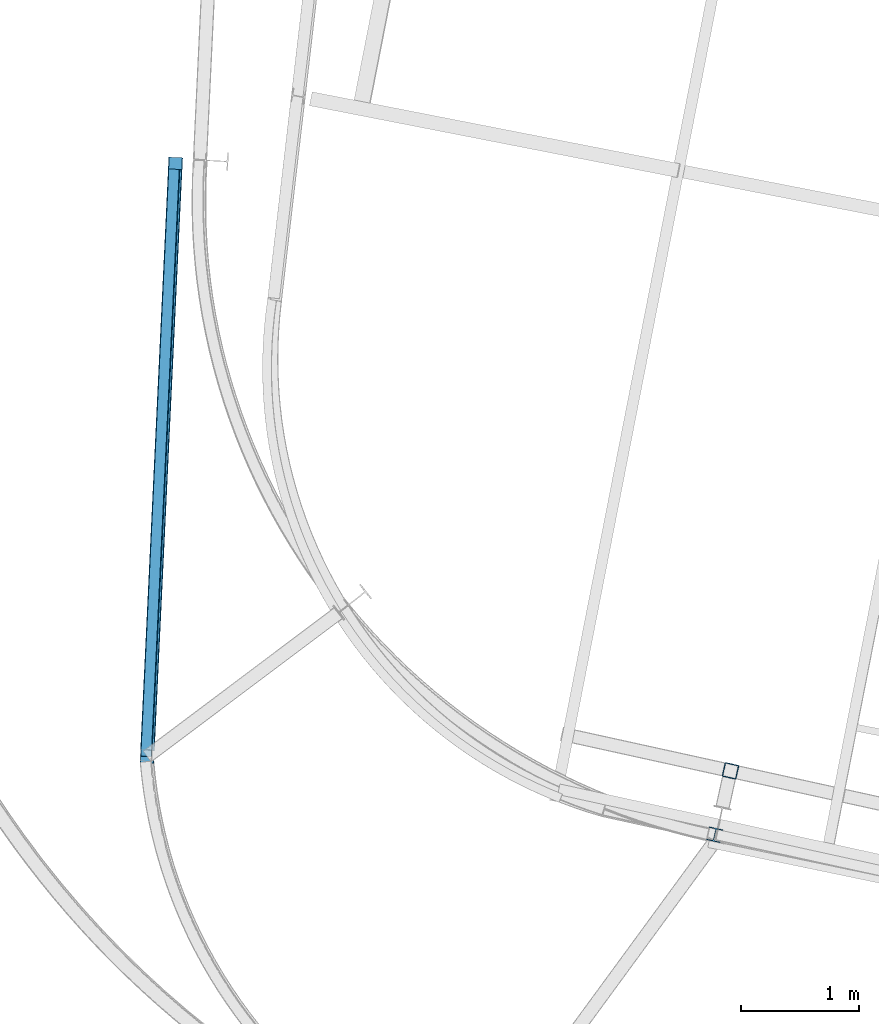
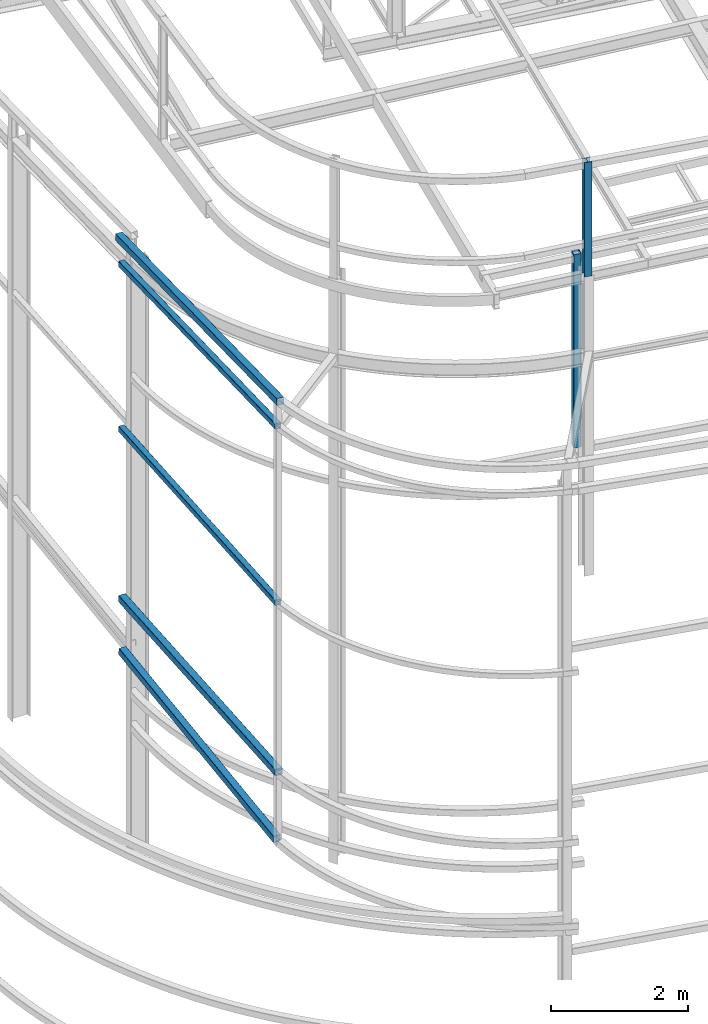
# One storey, part 18 of 215: 7 beams, 7 elements without a shape of their own.
"""IFC2X3 building model written with IfcOpenShell, lengths in millimetres."""

from ifc_helpers import new_model, si_unit, frame, origin_with_axes, origin_2d_with_axis, place, context, subcontext, project, spatial, hollow_rectangle, i_section, extrude, material, type_object, element, aggregate, save


model = new_model("IFC2X3")

# Units and contexts
model_context = context("Model", 3, precision=1e-05, world=origin_with_axes())
body_context = subcontext(model_context, "Body", "Model", "MODEL_VIEW")
ifc_project = project(units=[si_unit("LENGTHUNIT", "METRE", prefix="MILLI"), si_unit("AREAUNIT", "SQUARE_METRE"), si_unit("VOLUMEUNIT", "CUBIC_METRE"), si_unit("MASSUNIT", "GRAM", prefix="KILO"), si_unit("TIMEUNIT", "SECOND"), si_unit("PLANEANGLEUNIT", "RADIAN"), si_unit("SOLIDANGLEUNIT", "STERADIAN"), si_unit("THERMODYNAMICTEMPERATUREUNIT", "DEGREE_CELSIUS"), si_unit("LUMINOUSINTENSITYUNIT", "LUMEN")], contexts=[model_context])

# Site, building, storey
site_placement = place(None, origin_with_axes())
site = spatial("IfcSite", under=ifc_project, at=site_placement, CompositionType="ELEMENT")
building_placement = place(site_placement, origin_with_axes())
building = spatial("IfcBuilding", under=site, at=building_placement, Name="Undefined", CompositionType="ELEMENT")
storey_placement = place(building_placement, origin_with_axes())
storey = spatial("IfcBuildingStorey", under=building, at=storey_placement, Name="Undefined", CompositionType="ELEMENT", Elevation=0.0)

# Assembly, beam
assembly_1_placement = place(storey_placement, origin_with_axes())
assembly_1 = element("IfcElementAssembly", 1, at=assembly_1_placement, inside=storey, Name="Steel Assembly", AssemblyPlace="NOTDEFINED", PredefinedType="RIGID_FRAME")
ifc_material = material(Name="STEEL/S275JR")
beam_type_1 = type_object("IfcBeamType", PredefinedType="NOTDEFINED")
beam_1_placement = place(assembly_1_placement, frame((36795.3247404599, 11460.41995252, 11240.3737871053), z_axis=(0.00238075000008834, 0.049957779001925, 0.998748493038479), x_axis=(0.0475416480028052, 0.997616331058868, -0.0500144750029513)))
beam_1 = element("IfcBeam", 2, at=beam_1_placement, type_object=beam_type_1, material=ifc_material, Name="LISSE", context=body_context, shape_type="SweptSolid", body=[
    extrude(hollow_rectangle(XDim=120.0, YDim=120.0, WallThickness=4.0, InnerFilletRadius=4.0, OuterFilletRadius=8.0, at=origin_2d_with_axis()), frame((5139.48581661668, 7.27365367368595e-12, -5.45696821063757e-12), z_axis=(-1.0, 0.0, 0.0), x_axis=(-6.93889390390723e-18, -1.0, -3.46944695195361e-18)), (0.0, 0.0, 1.0), 5139.5),
])
aggregate(assembly_1, [beam_1])

assembly_2_placement = place(storey_placement, origin_with_axes())
assembly_2 = element("IfcElementAssembly", 3, at=assembly_2_placement, inside=storey, Name="Steel Assembly", AssemblyPlace="NOTDEFINED", PredefinedType="RIGID_FRAME")
beam_type_2 = type_object("IfcBeamType", PredefinedType="NOTDEFINED")
beam_2_placement = place(assembly_2_placement, frame((41739.3919223138, 11394.2173397851, 12210.2118217111), z_axis=(-0.214538758981639, -0.97671547591641, 0.0), x_axis=(0.0, 0.0, -1.0)))
beam_2 = element("IfcBeam", 4, at=beam_2_placement, type_object=beam_type_2, material=ifc_material, Name="LISSE", context=body_context, shape_type="SweptSolid", body=[
    extrude(hollow_rectangle(XDim=120.0, YDim=120.0, WallThickness=5.0, InnerFilletRadius=5.0, OuterFilletRadius=10.0, at=origin_2d_with_axis()), frame((3444.21098008439, 7.2759576369753e-12, 3.73929221960184e-21), z_axis=(-1.0, 0.0, 0.0), x_axis=(-6.93889390390723e-18, -1.0, -3.46944695195361e-18)), (0.0, 0.0, 1.0), 3444.2),
])
aggregate(assembly_2, [beam_2])

assembly_3_placement = place(storey_placement, origin_with_axes())
assembly_3 = element("IfcElementAssembly", 5, at=assembly_3_placement, inside=storey, Name="Steel Assembly", AssemblyPlace="NOTDEFINED", PredefinedType="RIGID_FRAME")
beam_3_placement = place(assembly_3_placement, frame((36800.4836915666, 11570.7503925782, 3388.42358772173), z_axis=(-0.00280173800110912, -0.0584249270230884, 0.998287873394503), x_axis=(0.047541444015522, 0.997155198325569, 0.0584920640190976)))
beam_3 = element("IfcBeam", 6, at=beam_3_placement, type_object=beam_type_2, material=ifc_material, Name="LISSE", context=body_context, shape_type="SweptSolid", body=[
    extrude(hollow_rectangle(XDim=120.0, YDim=120.0, WallThickness=5.0, InnerFilletRadius=5.0, OuterFilletRadius=10.0, at=origin_2d_with_axis()), frame((4926.01569208884, -3.74450364960788e-14, -9.09494701772928e-13), z_axis=(-1.0, 0.0, 0.0), x_axis=(-6.93889390390723e-18, -1.0, -3.46944695195361e-18)), (0.0, 0.0, 1.0), 4926.0),
])
aggregate(assembly_3, [beam_3])

assembly_4_placement = place(storey_placement, origin_with_axes())
assembly_4 = element("IfcElementAssembly", 7, at=assembly_4_placement, inside=storey, Name="Steel Assembly", AssemblyPlace="NOTDEFINED", PredefinedType="RIGID_FRAME")
beam_4_placement = place(assembly_4_placement, frame((36798.0156396208, 11516.4725905369, 4609.93424743849), z_axis=(3.64340000136608e-05, -1.73599999892668e-06, 0.999999999334775), x_axis=(0.0475972750198219, 0.998866607415969, 0.0)))
beam_4 = element("IfcBeam", 8, at=beam_4_placement, type_object=beam_type_2, material=ifc_material, Name="LISSE", context=body_context, shape_type="SweptSolid", body=[
    extrude(hollow_rectangle(XDim=120.0, YDim=120.0, WallThickness=5.0, InnerFilletRadius=5.0, OuterFilletRadius=10.0, at=origin_2d_with_axis()), frame((4980.06278256892, 6.91122545660855e-14, -9.09496810911556e-13), z_axis=(-1.0, 0.0, 0.0), x_axis=(-6.93889390390723e-18, -1.0, -3.46944695195361e-18)), (0.0, 0.0, 1.0), 4980.1),
])
aggregate(assembly_4, [beam_4])

assembly_5_placement = place(storey_placement, origin_with_axes())
assembly_5 = element("IfcElementAssembly", 9, at=assembly_5_placement, inside=storey, Name="Steel Assembly", AssemblyPlace="NOTDEFINED", PredefinedType="RIGID_FRAME")
beam_type_3 = type_object("IfcBeamType", PredefinedType="NOTDEFINED")
beam_5_placement = place(assembly_5_placement, frame((36788.0269735693, 11516.9485629643, 7631.86876990077), z_axis=(3.64340000136608e-05, -1.73599999892668e-06, 0.999999999334775), x_axis=(0.0475972750198219, 0.998866607415969, 0.0)))
beam_5 = element("IfcBeam", 10, at=beam_5_placement, type_object=beam_type_3, material=ifc_material, Name="LISSE", context=body_context, shape_type="SweptSolid", body=[
    extrude(hollow_rectangle(XDim=100.0, YDim=100.0, WallThickness=5.0, InnerFilletRadius=5.0, OuterFilletRadius=10.0, at=origin_2d_with_axis()), frame((4980.06278256892, 6.91122545660855e-14, -9.09496810911556e-13), z_axis=(-1.0, 0.0, 0.0), x_axis=(-6.93889390390723e-18, -1.0, -3.46944695195361e-18)), (0.0, 0.0, 1.0), 4980.1),
])
aggregate(assembly_5, [beam_5])

assembly_6_placement = place(storey_placement, origin_with_axes())
assembly_6 = element("IfcElementAssembly", 11, at=assembly_6_placement, inside=storey, Name="Steel Assembly", AssemblyPlace="NOTDEFINED", PredefinedType="RIGID_FRAME")
beam_6_placement = place(assembly_6_placement, frame((36788.0523458803, 11517.526792597, 10770.8511345843), z_axis=(0.0019443449994588, 0.0408032519885683, 0.999165308720074), x_axis=(0.0475579820174759, 0.998032841366755, -0.0408495520150112)))
beam_6 = element("IfcBeam", 12, at=beam_6_placement, type_object=beam_type_3, material=ifc_material, Name="LISSE", context=body_context, shape_type="SweptSolid", body=[
    extrude(hollow_rectangle(XDim=100.0, YDim=100.0, WallThickness=5.0, InnerFilletRadius=5.0, OuterFilletRadius=10.0, at=origin_2d_with_axis()), frame((4981.59959934075, 6.29416870974404e-15, 0.0), z_axis=(-1.0, 0.0, 0.0), x_axis=(-6.93889390390723e-18, -1.0, -3.46944695195361e-18)), (0.0, 0.0, 1.0), 4981.6),
])
aggregate(assembly_6, [beam_6])

assembly_7_placement = place(storey_placement, origin_with_axes())
assembly_7 = element("IfcElementAssembly", 13, at=assembly_7_placement, inside=storey, Name="Steel Assembly", AssemblyPlace="NOTDEFINED", PredefinedType="RIGID_FRAME")
beam_type_4 = type_object("IfcBeamType", Name="HEA120", PredefinedType="NOTDEFINED")
beam_7_placement = place(assembly_7_placement, frame((41605.1616488242, 10853.1597068517, 14219.2652783817), z_axis=(0.214537767913723, 0.976715693607202, 1.00000033813359e-09), x_axis=(0.0, 0.0, -1.0)))
beam_7 = element("IfcBeam", 14, at=beam_7_placement, type_object=beam_type_4, material=ifc_material, ObjectType="HEA120", context=body_context, shape_type="SweptSolid", body=[
    extrude(i_section(OverallWidth=120.0, OverallDepth=114.0, WebThickness=5.0, FlangeThickness=8.0, FilletRadius=12.0, at=origin_2d_with_axis()), frame((2034.95141235966, 7.27595761376261e-12, 2.10409044473914e-22), z_axis=(-1.0, 0.0, 0.0), x_axis=(-6.93889390390723e-18, -1.0, -3.46944695195361e-18)), (0.0, 0.0, 1.0), 2035.0),
])
aggregate(assembly_7, [beam_7])

save(model, "model.ifc")
